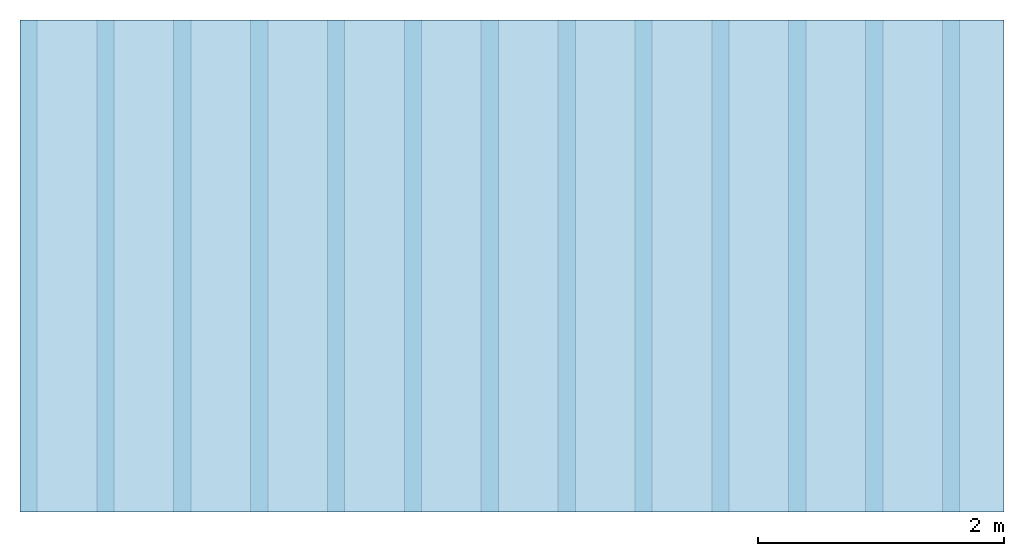
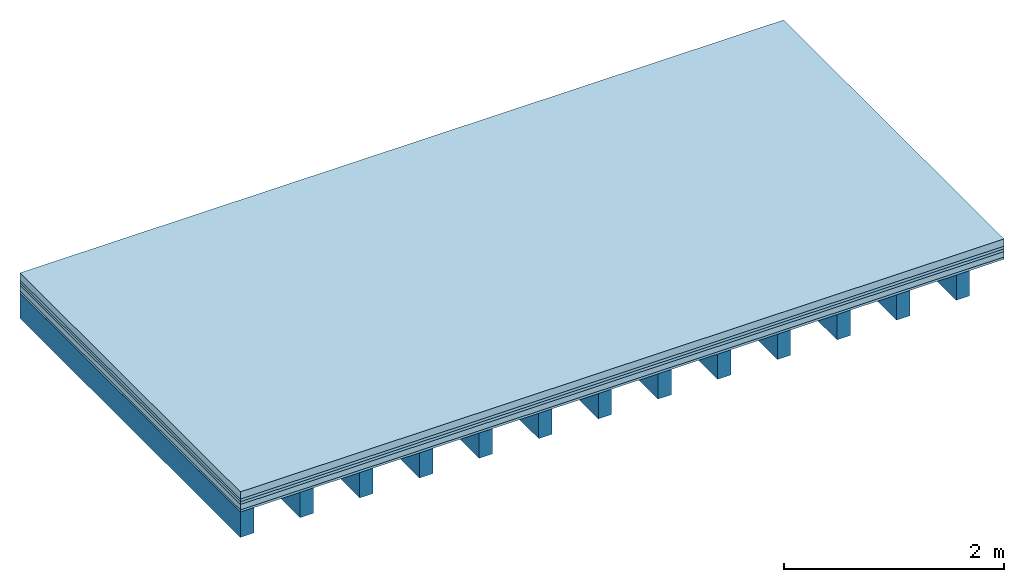
# One storey: 5 plates, 1 member, 1 element without a shape of its own.
"""IFC4 building model written with IfcOpenShell, lengths in metres."""

from ifc_helpers import new_model, si_unit, derived_unit, direction, frame, frame_2d, origin, origin_with_axes, place, context, project, spatial, rectangle, extrude, material, layer, layer_set, type_object, element, aggregate, save


model = new_model("IFC4")

# Units and contexts
plan_context = context("Plan", 3, precision=1e-05, world=origin(), true_north=direction((0.0, 1.0)))
model_context = context("Model", 3, precision=1e-05, world=origin(), true_north=direction((0.0, 1.0)))
ifc_project = project(units=[si_unit("LENGTHUNIT", "METRE"), derived_unit("SOUNDPRESSUREUNIT", [(si_unit("PRESSUREUNIT", "PASCAL", prefix="MICRO"), 0)]), si_unit("ENERGYUNIT", "JOULE", prefix="MEGA"), si_unit("MASSUNIT", "GRAM", prefix="KILO"), derived_unit("THERMALTRANSMITTANCEUNIT", [(si_unit("POWERUNIT", "WATT"), 1), (si_unit("AREAUNIT", "SQUARE_METRE"), -1), (si_unit("THERMODYNAMICTEMPERATUREUNIT", "KELVIN"), -1)]), derived_unit("AREADENSITYUNIT", [(si_unit("MASSUNIT", "GRAM", prefix="KILO"), 1), (si_unit("AREAUNIT", "SQUARE_METRE"), -1)]), derived_unit("USERDEFINED", [(si_unit("ENERGYUNIT", "JOULE", prefix="MEGA"), 1), (si_unit("AREAUNIT", "SQUARE_METRE"), -1)])], contexts=[plan_context, model_context])

# Site, building, storey
site = spatial("IfcSite", under=ifc_project)
building_placement = place(None, origin())
building = spatial("IfcBuilding", under=site, at=building_placement)
storey_placement = place(building_placement, origin())
storey = spatial("IfcBuildingStorey", under=building, at=storey_placement)

# Slab, member, plates
ifc_material_1 = material(Name="Cement screed", Category="04.006")
ifc_layer_1 = layer(ifc_material_1, 0.08, Name="On-material")
ifc_material_2 = material()
ifc_layer_2 = layer(ifc_material_2, 0.03, Name="Impact sound insulation")
ifc_material_3 = material()
ifc_layer_3 = layer(ifc_material_3, 0.03, Name="Additional insulation")
ifc_material_4 = material(Name="Cement panels, glued on sub-floor", Category="02.007")
ifc_layer_4 = layer(ifc_material_4, 0.06, Name="on Supporting structure")
ifc_material_5 = material(Category="07.001")
ifc_layer_5 = layer(ifc_material_5, 0.025, Name="Sub-floor")
ifc_material_6 = material(Name="of the art")
ifc_layer_6 = layer(ifc_material_6, 0.0, Name="Bond")
ifc_layer_7 = layer(None, 0.28, Name="Supporting structure")
ifc_layer_set = layer_set([ifc_layer_1, ifc_layer_2, ifc_layer_3, ifc_layer_4, ifc_layer_5, ifc_layer_6, ifc_layer_7])
slab_type = type_object("IfcSlabType", Name="A0225", PredefinedType="NOTDEFINED", material=ifc_layer_set)
slab_placement = place(None, frame((0.0, 0.0, 0.0), z_axis=(0.0, 0.0, -1.0), x_axis=(1.0, 0.0, 0.0)))
slab = element("IfcSlab", 1, at=slab_placement, inside=storey, type_object=slab_type, material=ifc_layer_set, Name="Slab #1")
ifc_material_7 = material()
member_placement = place(slab_placement, origin())
member = element("IfcMember", 2, at=member_placement, material=ifc_material_7, Name="Supporting structure", context=plan_context, shape_type="SweptSolid", body=[
    extrude(rectangle(XDim=0.14, YDim=0.28, at=frame_2d((0.07, 0.14), x_axis=(1.0, 0.0))), frame((0.0, 4.0, 0.225), z_axis=(0.0, -1.0, 0.0), x_axis=(1.0, 0.0, 0.0)), (0.0, 0.0, 1.0), 4.0),
    extrude(rectangle(XDim=0.14, YDim=0.28, at=frame_2d((0.07, 0.14), x_axis=(1.0, 0.0))), frame((0.625, 4.0, 0.225), z_axis=(0.0, -1.0, 0.0), x_axis=(1.0, 0.0, 0.0)), (0.0, 0.0, 1.0), 4.0),
    extrude(rectangle(XDim=0.14, YDim=0.28, at=frame_2d((0.07, 0.14), x_axis=(1.0, 0.0))), frame((1.25, 4.0, 0.225), z_axis=(0.0, -1.0, 0.0), x_axis=(1.0, 0.0, 0.0)), (0.0, 0.0, 1.0), 4.0),
    extrude(rectangle(XDim=0.14, YDim=0.28, at=frame_2d((0.07, 0.14), x_axis=(1.0, 0.0))), frame((1.875, 4.0, 0.225), z_axis=(0.0, -1.0, 0.0), x_axis=(1.0, 0.0, 0.0)), (0.0, 0.0, 1.0), 4.0),
    extrude(rectangle(XDim=0.14, YDim=0.28, at=frame_2d((0.07, 0.14), x_axis=(1.0, 0.0))), frame((2.5, 4.0, 0.225), z_axis=(0.0, -1.0, 0.0), x_axis=(1.0, 0.0, 0.0)), (0.0, 0.0, 1.0), 4.0),
    extrude(rectangle(XDim=0.14, YDim=0.28, at=frame_2d((0.07, 0.14), x_axis=(1.0, 0.0))), frame((3.125, 4.0, 0.225), z_axis=(0.0, -1.0, 0.0), x_axis=(1.0, 0.0, 0.0)), (0.0, 0.0, 1.0), 4.0),
    extrude(rectangle(XDim=0.14, YDim=0.28, at=frame_2d((0.07, 0.14), x_axis=(1.0, 0.0))), frame((3.75, 4.0, 0.225), z_axis=(0.0, -1.0, 0.0), x_axis=(1.0, 0.0, 0.0)), (0.0, 0.0, 1.0), 4.0),
    extrude(rectangle(XDim=0.14, YDim=0.28, at=frame_2d((0.07, 0.14), x_axis=(1.0, 0.0))), frame((4.375, 4.0, 0.225), z_axis=(0.0, -1.0, 0.0), x_axis=(1.0, 0.0, 0.0)), (0.0, 0.0, 1.0), 4.0),
    extrude(rectangle(XDim=0.14, YDim=0.28, at=frame_2d((0.07, 0.14), x_axis=(1.0, 0.0))), frame((5.0, 4.0, 0.225), z_axis=(0.0, -1.0, 0.0), x_axis=(1.0, 0.0, 0.0)), (0.0, 0.0, 1.0), 4.0),
    extrude(rectangle(XDim=0.14, YDim=0.28, at=frame_2d((0.07, 0.14), x_axis=(1.0, 0.0))), frame((5.625, 4.0, 0.225), z_axis=(0.0, -1.0, 0.0), x_axis=(1.0, 0.0, 0.0)), (0.0, 0.0, 1.0), 4.0),
    extrude(rectangle(XDim=0.14, YDim=0.28, at=frame_2d((0.07, 0.14), x_axis=(1.0, 0.0))), frame((6.25, 4.0, 0.225), z_axis=(0.0, -1.0, 0.0), x_axis=(1.0, 0.0, 0.0)), (0.0, 0.0, 1.0), 4.0),
    extrude(rectangle(XDim=0.14, YDim=0.28, at=frame_2d((0.07, 0.14), x_axis=(1.0, 0.0))), frame((6.875, 4.0, 0.225), z_axis=(0.0, -1.0, 0.0), x_axis=(1.0, 0.0, 0.0)), (0.0, 0.0, 1.0), 4.0),
    extrude(rectangle(XDim=0.14, YDim=0.28, at=frame_2d((0.07, 0.14), x_axis=(1.0, 0.0))), frame((7.5, 4.0, 0.225), z_axis=(0.0, -1.0, 0.0), x_axis=(1.0, 0.0, 0.0)), (0.0, 0.0, 1.0), 4.0),
])
plate_1_placement = place(slab_placement, origin())
plate_1 = element("IfcPlate", 3, at=plate_1_placement, material=ifc_material_1, Name="On-material", context=plan_context, shape_type="SweptSolid", body=[
    extrude(rectangle(XDim=8.0, YDim=4.0, at=frame_2d((4.0, 2.0), x_axis=(1.0, 0.0))), origin_with_axes(), (0.0, 0.0, 1.0), 0.08),
])
plate_2_placement = place(slab_placement, origin())
plate_2 = element("IfcPlate", 4, at=plate_2_placement, material=ifc_material_2, Name="Impact sound insulation", context=plan_context, shape_type="SweptSolid", body=[
    extrude(rectangle(XDim=8.0, YDim=4.0, at=frame_2d((4.0, 2.0), x_axis=(1.0, 0.0))), frame((0.0, 0.0, 0.08), z_axis=(0.0, 0.0, 1.0), x_axis=(1.0, 0.0, 0.0)), (0.0, 0.0, 1.0), 0.03),
])
plate_3_placement = place(slab_placement, origin())
plate_3 = element("IfcPlate", 5, at=plate_3_placement, material=ifc_material_3, Name="Additional insulation", context=plan_context, shape_type="SweptSolid", body=[
    extrude(rectangle(XDim=8.0, YDim=4.0, at=frame_2d((4.0, 2.0), x_axis=(1.0, 0.0))), frame((0.0, 0.0, 0.11), z_axis=(0.0, 0.0, 1.0), x_axis=(1.0, 0.0, 0.0)), (0.0, 0.0, 1.0), 0.03),
])
plate_4_placement = place(slab_placement, origin())
plate_4 = element("IfcPlate", 6, at=plate_4_placement, material=ifc_material_4, Name="on Supporting structure", context=plan_context, shape_type="SweptSolid", body=[
    extrude(rectangle(XDim=8.0, YDim=4.0, at=frame_2d((4.0, 2.0), x_axis=(1.0, 0.0))), frame((0.0, 0.0, 0.14), z_axis=(0.0, 0.0, 1.0), x_axis=(1.0, 0.0, 0.0)), (0.0, 0.0, 1.0), 0.06),
])
plate_5_placement = place(slab_placement, origin())
plate_5 = element("IfcPlate", 7, at=plate_5_placement, material=ifc_material_5, Name="Sub-floor", context=plan_context, shape_type="SweptSolid", body=[
    extrude(rectangle(XDim=8.0, YDim=4.0, at=frame_2d((4.0, 2.0), x_axis=(1.0, 0.0))), frame((0.0, 0.0, 0.2), z_axis=(0.0, 0.0, 1.0), x_axis=(1.0, 0.0, 0.0)), (0.0, 0.0, 1.0), 0.025),
])
aggregate(slab, [plate_1, plate_2, plate_3, plate_4, plate_5, member])

save(model, "model.ifc")
